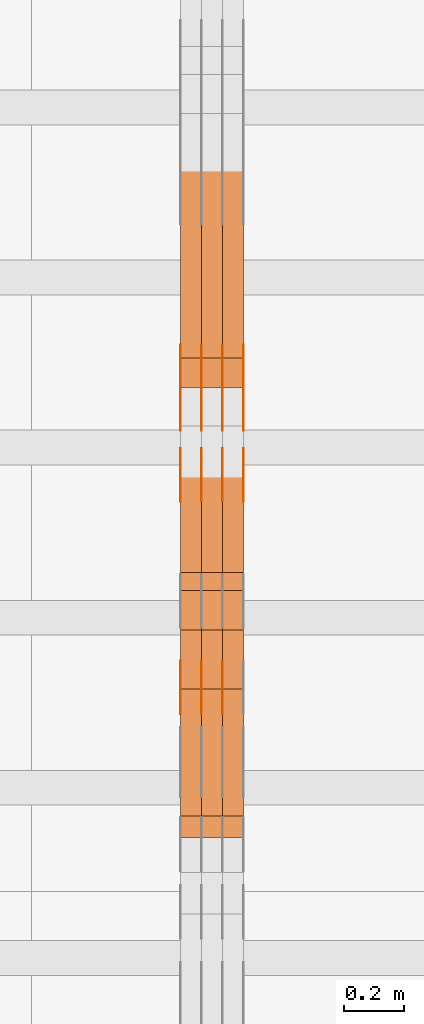
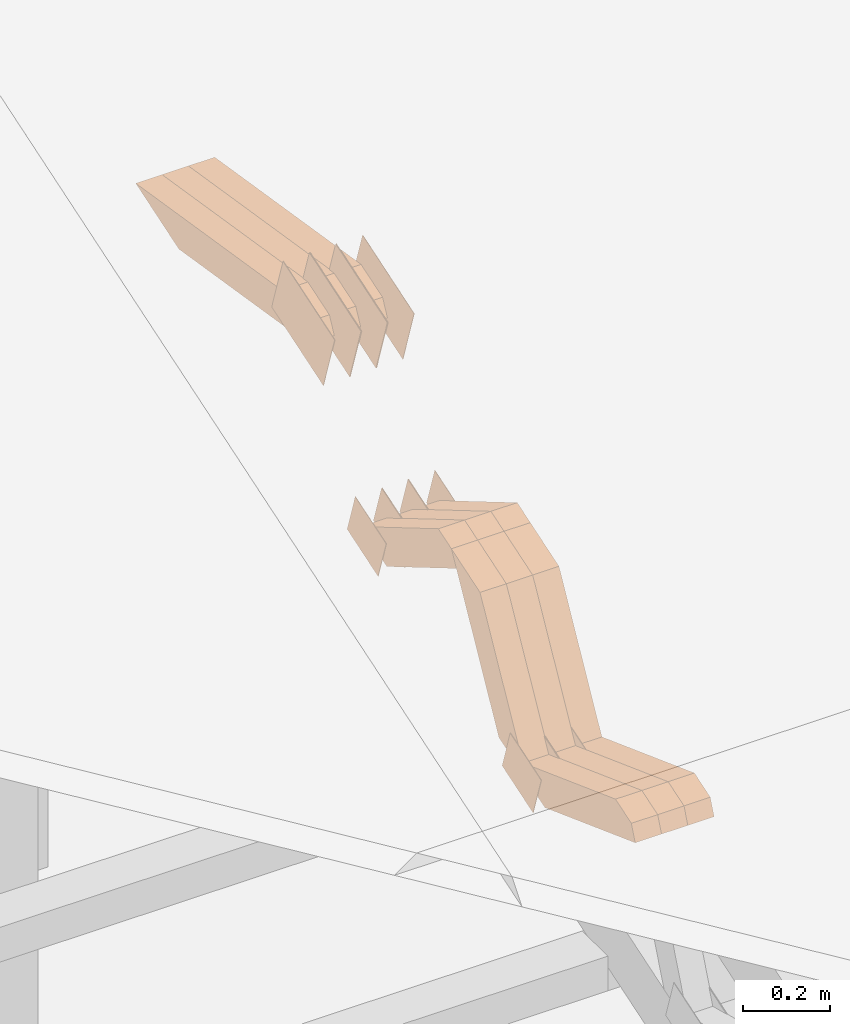
# One storey, part 71 of 385: 28 proxies.
"""IFC2X3 building model written with IfcOpenShell, lengths in millimetres."""

from ifc_helpers import new_model, entity, si_unit, converted_unit, derived_unit, direction, frame, origin, place, context, subcontext, project, spatial, polyline, outline, extrude, source, transform, mapped, material, type_object, type_shapes, element, save


model = new_model("IFC2X3")

# Units and contexts
model_context = context("Model", 3, precision=0.01, world=origin(), true_north=direction((6.12303176911189e-17, 1.0)))
body_context = subcontext(model_context, "Body", "Model", "MODEL_VIEW")
ifc_project = project(units=[si_unit("LENGTHUNIT", "METRE", prefix="MILLI"), si_unit("AREAUNIT", "SQUARE_METRE"), si_unit("VOLUMEUNIT", "CUBIC_METRE"), converted_unit("PLANEANGLEUNIT", "DEGREE", entity("IfcRatioMeasure", 0.0174532925199433), si_unit("PLANEANGLEUNIT", "RADIAN"), dimensions=[0, 0, 0, 0, 0, 0, 0]), si_unit("MASSUNIT", "GRAM", prefix="KILO"), derived_unit("MASSDENSITYUNIT", [(si_unit("MASSUNIT", "GRAM", prefix="KILO"), 1), (si_unit("LENGTHUNIT", "METRE"), -3)]), si_unit("TIMEUNIT", "SECOND"), si_unit("FREQUENCYUNIT", "HERTZ"), si_unit("THERMODYNAMICTEMPERATUREUNIT", "DEGREE_CELSIUS"), derived_unit("THERMALTRANSMITTANCEUNIT", [(si_unit("MASSUNIT", "GRAM", prefix="KILO"), 1), (si_unit("THERMODYNAMICTEMPERATUREUNIT", "KELVIN"), -1), (si_unit("TIMEUNIT", "SECOND"), -3)]), derived_unit("VOLUMETRICFLOWRATEUNIT", [(si_unit("LENGTHUNIT", "METRE"), 3), (si_unit("TIMEUNIT", "SECOND"), -1)]), si_unit("ELECTRICCURRENTUNIT", "AMPERE"), si_unit("ELECTRICVOLTAGEUNIT", "VOLT"), si_unit("POWERUNIT", "WATT"), si_unit("FORCEUNIT", "NEWTON", prefix="KILO"), si_unit("ILLUMINANCEUNIT", "LUX"), si_unit("LUMINOUSFLUXUNIT", "LUMEN"), si_unit("LUMINOUSINTENSITYUNIT", "CANDELA"), derived_unit("USERDEFINED", [(si_unit("MASSUNIT", "GRAM", prefix="KILO"), -1), (si_unit("LENGTHUNIT", "METRE"), -2), (si_unit("TIMEUNIT", "SECOND"), 3), (si_unit("LUMINOUSFLUXUNIT", "LUMEN"), 1)]), derived_unit("LINEARVELOCITYUNIT", [(si_unit("LENGTHUNIT", "METRE"), 1), (si_unit("TIMEUNIT", "SECOND"), -1)]), si_unit("PRESSUREUNIT", "PASCAL"), derived_unit("USERDEFINED", [(si_unit("LENGTHUNIT", "METRE"), -2), (si_unit("MASSUNIT", "GRAM", prefix="KILO"), 1), (si_unit("TIMEUNIT", "SECOND"), -2)])], contexts=[model_context])

# Site, building, storey
site_placement = place(None, origin())
site = spatial("IfcSite", under=ifc_project, at=site_placement, CompositionType="ELEMENT")
building_placement = place(site_placement, origin())
building = spatial("IfcBuilding", under=site, at=building_placement, CompositionType="ELEMENT")
storey_placement = place(building_placement, origin())
storey = spatial("IfcBuildingStorey", under=building, at=storey_placement, Name="Default", CompositionType="ELEMENT", Elevation=0.0)

# Proxies
ifc_material_1 = material(Name="IfcSurfaceStyle #175620")
building_element_proxy_type_1 = type_object("IfcBuildingElementProxyType", PredefinedType="NOTDEFINED", material=ifc_material_1)
shared_shape_1 = source(origin(), body_context, "Body", "SweptSolid", [
    extrude(outline(polyline([(-75.0008041947458, -59.9996998629349), (75.0007893252423, -59.9996998629349), (75.0008041947458, 59.9996998629349), (-75.0007893252423, 59.9996998629349), (-75.0008041947458, -59.9996998629349)])), frame((75.0008041947458, 60.0002282421692, 0.0), z_axis=(0.0, 0.0, 1.0), x_axis=(-1.0, 0.0, 0.0)), (0.0, 0.0, 1.0), 1.3),
])
type_shapes(building_element_proxy_type_1, [shared_shape_1])
proxy_1_placement = place(building_placement, frame((12316.3, 9291.048828125, 2194.94482421875), z_axis=(-1.0, 0.0, 0.0), x_axis=(0.0, 0.951056516295124, 0.309016994375039)))
element("IfcBuildingElementProxy", 1, at=proxy_1_placement, inside=storey, type_object=building_element_proxy_type_1, material=ifc_material_1, context=body_context, shape_type="MappedRepresentation", body=[
    mapped(shared_shape_1, transform((0.0, 0.0, 0.0), scale=1.0)),
])
ifc_material_2 = material(Name="IfcSurfaceStyle #175563")
building_element_proxy_type_2 = type_object("IfcBuildingElementProxyType", PredefinedType="NOTDEFINED", material=ifc_material_2)
shared_shape_2 = source(origin(), body_context, "Body", "SweptSolid", [
    extrude(outline(polyline([(-75.0008041947458, -59.9996998629349), (75.0007893252423, -59.9996998629349), (75.0008041947458, 59.9996998629349), (-75.0007893252423, 59.9996998629349), (-75.0008041947458, -59.9996998629349)])), frame((75.0008041947458, 60.0002282421692, 0.0), z_axis=(0.0, 0.0, 1.0), x_axis=(-1.0, 0.0, 0.0)), (0.0, 0.0, 1.0), 1.29999999999999),
])
type_shapes(building_element_proxy_type_2, [shared_shape_2])
proxy_2_placement = place(building_placement, frame((12245.0, 9291.048828125, 2194.94482421875), z_axis=(-1.0, 0.0, 0.0), x_axis=(0.0, 0.951056516295124, 0.309016994375039)))
element("IfcBuildingElementProxy", 2, at=proxy_2_placement, inside=storey, type_object=building_element_proxy_type_2, material=ifc_material_2, context=body_context, shape_type="MappedRepresentation", body=[
    mapped(shared_shape_2, transform((0.0, 0.0, 0.0), scale=1.0)),
])
ifc_material_3 = material(Name="IfcSurfaceStyle #175506")
building_element_proxy_type_3 = type_object("IfcBuildingElementProxyType", PredefinedType="NOTDEFINED", material=ifc_material_3)
shared_shape_3 = source(origin(), body_context, "Body", "SweptSolid", [
    extrude(outline(polyline([(-75.0008041947458, -59.9996998629349), (75.0007893252423, -59.9996998629349), (75.0008041947458, 59.9996998629349), (-75.0007893252423, 59.9996998629349), (-75.0008041947458, -59.9996998629349)])), frame((75.0008041947458, 60.0002282421692, 0.0), z_axis=(0.0, 0.0, 1.0), x_axis=(-1.0, 0.0, 0.0)), (0.0, 0.0, 1.0), 1.29999999999999),
])
type_shapes(building_element_proxy_type_3, [shared_shape_3])
proxy_3_placement = place(building_placement, frame((12246.3, 9291.048828125, 2194.94482421875), z_axis=(-1.0, 0.0, 0.0), x_axis=(0.0, 0.951056516295124, 0.309016994375039)))
element("IfcBuildingElementProxy", 3, at=proxy_3_placement, inside=storey, type_object=building_element_proxy_type_3, material=ifc_material_3, context=body_context, shape_type="MappedRepresentation", body=[
    mapped(shared_shape_3, transform((0.0, 0.0, 0.0), scale=1.0)),
])
ifc_material_4 = material(Name="IfcSurfaceStyle #175449")
building_element_proxy_type_4 = type_object("IfcBuildingElementProxyType", PredefinedType="NOTDEFINED", material=ifc_material_4)
shared_shape_4 = source(origin(), body_context, "Body", "SweptSolid", [
    extrude(outline(polyline([(-75.0008041947458, -59.9996998629349), (75.0007893252423, -59.9996998629349), (75.0008041947458, 59.9996998629349), (-75.0007893252423, 59.9996998629349), (-75.0008041947458, -59.9996998629349)])), frame((75.0008041947458, 60.0002282421692, 0.0), z_axis=(0.0, 0.0, 1.0), x_axis=(-1.0, 0.0, 0.0)), (0.0, 0.0, 1.0), 1.29999999999999),
])
type_shapes(building_element_proxy_type_4, [shared_shape_4])
proxy_4_placement = place(building_placement, frame((12175.0, 9291.048828125, 2194.94482421875), z_axis=(-1.0, 0.0, 0.0), x_axis=(0.0, 0.951056516295124, 0.309016994375039)))
element("IfcBuildingElementProxy", 4, at=proxy_4_placement, inside=storey, type_object=building_element_proxy_type_4, material=ifc_material_4, context=body_context, shape_type="MappedRepresentation", body=[
    mapped(shared_shape_4, transform((0.0, 0.0, 0.0), scale=1.0)),
])
ifc_material_5 = material(Name="IfcSurfaceStyle #175392")
building_element_proxy_type_5 = type_object("IfcBuildingElementProxyType", PredefinedType="NOTDEFINED", material=ifc_material_5)
shared_shape_5 = source(origin(), body_context, "Body", "SweptSolid", [
    extrude(outline(polyline([(-124.999432723313, -83.9999457831645), (125.000177551971, -83.9999457831645), (124.999395001513, 83.9999457831646), (-125.000139830171, 83.9999457831645), (-124.999432723313, -83.9999457831645)])), frame((125.000177551971, 84.0001194377192, 0.0), z_axis=(0.0, 0.0, 1.0), x_axis=(-1.0, 0.0, 0.0)), (0.0, 0.0, 1.0), 1.3),
])
type_shapes(building_element_proxy_type_5, [shared_shape_5])
proxy_5_placement = place(building_placement, frame((12386.3, 10242.0968435406, 2855.88278137571), z_axis=(-1.0, 0.0, 0.0), x_axis=(0.0, 0.951056516295154, 0.309016994374948)))
element("IfcBuildingElementProxy", 5, at=proxy_5_placement, inside=storey, type_object=building_element_proxy_type_5, material=ifc_material_5, context=body_context, shape_type="MappedRepresentation", body=[
    mapped(shared_shape_5, transform((0.0, 0.0, 0.0), scale=1.0)),
])
ifc_material_6 = material(Name="IfcSurfaceStyle #175335")
building_element_proxy_type_6 = type_object("IfcBuildingElementProxyType", PredefinedType="NOTDEFINED", material=ifc_material_6)
shared_shape_6 = source(origin(), body_context, "Body", "SweptSolid", [
    extrude(outline(polyline([(-124.999432723313, -83.9999457831645), (125.000177551971, -83.9999457831645), (124.999395001513, 83.9999457831646), (-125.000139830171, 83.9999457831645), (-124.999432723313, -83.9999457831645)])), frame((125.000177551971, 84.0001194377192, 0.0), z_axis=(0.0, 0.0, 1.0), x_axis=(-1.0, 0.0, 0.0)), (0.0, 0.0, 1.0), 1.3),
])
type_shapes(building_element_proxy_type_6, [shared_shape_6])
proxy_6_placement = place(building_placement, frame((12315.0, 10242.0968435406, 2855.88278137571), z_axis=(-1.0, 0.0, 0.0), x_axis=(0.0, 0.951056516295154, 0.309016994374948)))
element("IfcBuildingElementProxy", 6, at=proxy_6_placement, inside=storey, type_object=building_element_proxy_type_6, material=ifc_material_6, context=body_context, shape_type="MappedRepresentation", body=[
    mapped(shared_shape_6, transform((0.0, 0.0, 0.0), scale=1.0)),
])
ifc_material_7 = material(Name="IfcSurfaceStyle #175278")
building_element_proxy_type_7 = type_object("IfcBuildingElementProxyType", PredefinedType="NOTDEFINED", material=ifc_material_7)
shared_shape_7 = source(origin(), body_context, "Body", "SweptSolid", [
    extrude(outline(polyline([(-124.999432723313, -83.9999457831645), (125.000177551971, -83.9999457831645), (124.999395001513, 83.9999457831646), (-125.000139830171, 83.9999457831645), (-124.999432723313, -83.9999457831645)])), frame((125.000177551971, 84.0001194377192, 0.0), z_axis=(0.0, 0.0, 1.0), x_axis=(-1.0, 0.0, 0.0)), (0.0, 0.0, 1.0), 1.3),
])
type_shapes(building_element_proxy_type_7, [shared_shape_7])
proxy_7_placement = place(building_placement, frame((12316.3, 10242.0968435406, 2855.88278137571), z_axis=(-1.0, 0.0, 0.0), x_axis=(0.0, 0.951056516295154, 0.309016994374948)))
element("IfcBuildingElementProxy", 7, at=proxy_7_placement, inside=storey, type_object=building_element_proxy_type_7, material=ifc_material_7, context=body_context, shape_type="MappedRepresentation", body=[
    mapped(shared_shape_7, transform((0.0, 0.0, 0.0), scale=1.0)),
])
ifc_material_8 = material(Name="IfcSurfaceStyle #175221")
building_element_proxy_type_8 = type_object("IfcBuildingElementProxyType", PredefinedType="NOTDEFINED", material=ifc_material_8)
shared_shape_8 = source(origin(), body_context, "Body", "SweptSolid", [
    extrude(outline(polyline([(-124.999432723313, -83.9999457831645), (125.000177551971, -83.9999457831645), (124.999395001513, 83.9999457831646), (-125.000139830171, 83.9999457831645), (-124.999432723313, -83.9999457831645)])), frame((125.000177551971, 84.0001194377192, 0.0), z_axis=(0.0, 0.0, 1.0), x_axis=(-1.0, 0.0, 0.0)), (0.0, 0.0, 1.0), 1.29999999999998),
])
type_shapes(building_element_proxy_type_8, [shared_shape_8])
proxy_8_placement = place(building_placement, frame((12245.0, 10242.0968435406, 2855.88278137571), z_axis=(-1.0, 0.0, 0.0), x_axis=(0.0, 0.951056516295154, 0.309016994374948)))
element("IfcBuildingElementProxy", 8, at=proxy_8_placement, inside=storey, type_object=building_element_proxy_type_8, material=ifc_material_8, context=body_context, shape_type="MappedRepresentation", body=[
    mapped(shared_shape_8, transform((0.0, 0.0, 0.0), scale=1.0)),
])
ifc_material_9 = material(Name="IfcSurfaceStyle #175164")
building_element_proxy_type_9 = type_object("IfcBuildingElementProxyType", PredefinedType="NOTDEFINED", material=ifc_material_9)
shared_shape_9 = source(origin(), body_context, "Body", "SweptSolid", [
    extrude(outline(polyline([(-124.999432723313, -83.9999457831645), (125.000177551971, -83.9999457831645), (124.999395001513, 83.9999457831646), (-125.000139830171, 83.9999457831645), (-124.999432723313, -83.9999457831645)])), frame((125.000177551971, 84.0001194377192, 0.0), z_axis=(0.0, 0.0, 1.0), x_axis=(-1.0, 0.0, 0.0)), (0.0, 0.0, 1.0), 1.29999999999998),
])
type_shapes(building_element_proxy_type_9, [shared_shape_9])
proxy_9_placement = place(building_placement, frame((12246.3, 10242.0968435406, 2855.88278137571), z_axis=(-1.0, 0.0, 0.0), x_axis=(0.0, 0.951056516295154, 0.309016994374948)))
element("IfcBuildingElementProxy", 9, at=proxy_9_placement, inside=storey, type_object=building_element_proxy_type_9, material=ifc_material_9, context=body_context, shape_type="MappedRepresentation", body=[
    mapped(shared_shape_9, transform((0.0, 0.0, 0.0), scale=1.0)),
])
ifc_material_10 = material(Name="IfcSurfaceStyle #175107")
building_element_proxy_type_10 = type_object("IfcBuildingElementProxyType", PredefinedType="NOTDEFINED", material=ifc_material_10)
shared_shape_10 = source(origin(), body_context, "Body", "SweptSolid", [
    extrude(outline(polyline([(-124.999432723313, -83.9999457831645), (125.000177551971, -83.9999457831645), (124.999395001513, 83.9999457831646), (-125.000139830171, 83.9999457831645), (-124.999432723313, -83.9999457831645)])), frame((125.000177551971, 84.0001194377192, 0.0), z_axis=(0.0, 0.0, 1.0), x_axis=(-1.0, 0.0, 0.0)), (0.0, 0.0, 1.0), 1.29999999999998),
])
type_shapes(building_element_proxy_type_10, [shared_shape_10])
proxy_10_placement = place(building_placement, frame((12175.0, 10242.0968435406, 2855.88278137571), z_axis=(-1.0, 0.0, 0.0), x_axis=(0.0, 0.951056516295154, 0.309016994374948)))
element("IfcBuildingElementProxy", 10, at=proxy_10_placement, inside=storey, type_object=building_element_proxy_type_10, material=ifc_material_10, context=body_context, shape_type="MappedRepresentation", body=[
    mapped(shared_shape_10, transform((0.0, 0.0, 0.0), scale=1.0)),
])
ifc_material_11 = material(Name="IfcSurfaceStyle #173682")
building_element_proxy_type_11 = type_object("IfcBuildingElementProxyType", PredefinedType="NOTDEFINED", material=ifc_material_11)
shared_shape_11 = source(origin(), body_context, "Body", "SweptSolid", [
    extrude(outline(polyline([(-74.9998754286189, -60.0000016373433), (74.9998605591118, -60.0000016373433), (74.9998754286189, 60.0000016373433), (-74.9998605591118, 60.0000016373433), (-74.9998754286189, -60.0000016373433)])), frame((74.9999131819004, 60.0000016373433, 0.0), z_axis=(0.0, 0.0, 1.0), x_axis=(-1.0, 0.0, 0.0)), (0.0, 0.0, 1.0), 1.3),
])
type_shapes(building_element_proxy_type_11, [shared_shape_11])
proxy_11_placement = place(building_placement, frame((12386.3, 10004.8612689908, 2426.87628052724), z_axis=(-1.0, 0.0, 0.0), x_axis=(0.0, 0.951056516295124, 0.309016994375039)))
element("IfcBuildingElementProxy", 11, at=proxy_11_placement, inside=storey, type_object=building_element_proxy_type_11, material=ifc_material_11, context=body_context, shape_type="MappedRepresentation", body=[
    mapped(shared_shape_11, transform((0.0, 0.0, 0.0), scale=1.0)),
])
ifc_material_12 = material(Name="IfcSurfaceStyle #173625")
building_element_proxy_type_12 = type_object("IfcBuildingElementProxyType", PredefinedType="NOTDEFINED", material=ifc_material_12)
shared_shape_12 = source(origin(), body_context, "Body", "SweptSolid", [
    extrude(outline(polyline([(-74.9998754286189, -60.0000016373433), (74.9998605591118, -60.0000016373433), (74.9998754286189, 60.0000016373433), (-74.9998605591118, 60.0000016373433), (-74.9998754286189, -60.0000016373433)])), frame((74.9999131819004, 60.0000016373433, 0.0), z_axis=(0.0, 0.0, 1.0), x_axis=(-1.0, 0.0, 0.0)), (0.0, 0.0, 1.0), 1.3),
])
type_shapes(building_element_proxy_type_12, [shared_shape_12])
proxy_12_placement = place(building_placement, frame((12315.0, 10004.8612689908, 2426.87628052724), z_axis=(-1.0, 0.0, 0.0), x_axis=(0.0, 0.951056516295124, 0.309016994375039)))
element("IfcBuildingElementProxy", 12, at=proxy_12_placement, inside=storey, type_object=building_element_proxy_type_12, material=ifc_material_12, context=body_context, shape_type="MappedRepresentation", body=[
    mapped(shared_shape_12, transform((0.0, 0.0, 0.0), scale=1.0)),
])
ifc_material_13 = material(Name="IfcSurfaceStyle #173568")
building_element_proxy_type_13 = type_object("IfcBuildingElementProxyType", PredefinedType="NOTDEFINED", material=ifc_material_13)
shared_shape_13 = source(origin(), body_context, "Body", "SweptSolid", [
    extrude(outline(polyline([(-74.9998754286189, -60.0000016373433), (74.9998605591118, -60.0000016373433), (74.9998754286189, 60.0000016373433), (-74.9998605591118, 60.0000016373433), (-74.9998754286189, -60.0000016373433)])), frame((74.9999131819004, 60.0000016373433, 0.0), z_axis=(0.0, 0.0, 1.0), x_axis=(-1.0, 0.0, 0.0)), (0.0, 0.0, 1.0), 1.3),
])
type_shapes(building_element_proxy_type_13, [shared_shape_13])
proxy_13_placement = place(building_placement, frame((12316.3, 10004.8612689908, 2426.87628052724), z_axis=(-1.0, 0.0, 0.0), x_axis=(0.0, 0.951056516295124, 0.309016994375039)))
element("IfcBuildingElementProxy", 13, at=proxy_13_placement, inside=storey, type_object=building_element_proxy_type_13, material=ifc_material_13, context=body_context, shape_type="MappedRepresentation", body=[
    mapped(shared_shape_13, transform((0.0, 0.0, 0.0), scale=1.0)),
])
ifc_material_14 = material(Name="IfcSurfaceStyle #173511")
building_element_proxy_type_14 = type_object("IfcBuildingElementProxyType", PredefinedType="NOTDEFINED", material=ifc_material_14)
shared_shape_14 = source(origin(), body_context, "Body", "SweptSolid", [
    extrude(outline(polyline([(-74.9998754286189, -60.0000016373433), (74.9998605591118, -60.0000016373433), (74.9998754286189, 60.0000016373433), (-74.9998605591118, 60.0000016373433), (-74.9998754286189, -60.0000016373433)])), frame((74.9999131819004, 60.0000016373433, 0.0), z_axis=(0.0, 0.0, 1.0), x_axis=(-1.0, 0.0, 0.0)), (0.0, 0.0, 1.0), 1.29999999999999),
])
type_shapes(building_element_proxy_type_14, [shared_shape_14])
proxy_14_placement = place(building_placement, frame((12245.0, 10004.8612689908, 2426.87628052724), z_axis=(-1.0, 0.0, 0.0), x_axis=(0.0, 0.951056516295124, 0.309016994375039)))
element("IfcBuildingElementProxy", 14, at=proxy_14_placement, inside=storey, type_object=building_element_proxy_type_14, material=ifc_material_14, context=body_context, shape_type="MappedRepresentation", body=[
    mapped(shared_shape_14, transform((0.0, 0.0, 0.0), scale=1.0)),
])
ifc_material_15 = material(Name="IfcSurfaceStyle #173454")
building_element_proxy_type_15 = type_object("IfcBuildingElementProxyType", PredefinedType="NOTDEFINED", material=ifc_material_15)
shared_shape_15 = source(origin(), body_context, "Body", "SweptSolid", [
    extrude(outline(polyline([(-74.9998754286189, -60.0000016373433), (74.9998605591118, -60.0000016373433), (74.9998754286189, 60.0000016373433), (-74.9998605591118, 60.0000016373433), (-74.9998754286189, -60.0000016373433)])), frame((74.9999131819004, 60.0000016373433, 0.0), z_axis=(0.0, 0.0, 1.0), x_axis=(-1.0, 0.0, 0.0)), (0.0, 0.0, 1.0), 1.29999999999999),
])
type_shapes(building_element_proxy_type_15, [shared_shape_15])
proxy_15_placement = place(building_placement, frame((12246.3, 10004.8612689908, 2426.87628052724), z_axis=(-1.0, 0.0, 0.0), x_axis=(0.0, 0.951056516295124, 0.309016994375039)))
element("IfcBuildingElementProxy", 15, at=proxy_15_placement, inside=storey, type_object=building_element_proxy_type_15, material=ifc_material_15, context=body_context, shape_type="MappedRepresentation", body=[
    mapped(shared_shape_15, transform((0.0, 0.0, 0.0), scale=1.0)),
])
ifc_material_16 = material(Name="IfcSurfaceStyle #173397")
building_element_proxy_type_16 = type_object("IfcBuildingElementProxyType", PredefinedType="NOTDEFINED", material=ifc_material_16)
shared_shape_16 = source(origin(), body_context, "Body", "SweptSolid", [
    extrude(outline(polyline([(-74.9998754286189, -60.0000016373433), (74.9998605591118, -60.0000016373433), (74.9998754286189, 60.0000016373433), (-74.9998605591118, 60.0000016373433), (-74.9998754286189, -60.0000016373433)])), frame((74.9999131819004, 60.0000016373433, 0.0), z_axis=(0.0, 0.0, 1.0), x_axis=(-1.0, 0.0, 0.0)), (0.0, 0.0, 1.0), 1.29999999999999),
])
type_shapes(building_element_proxy_type_16, [shared_shape_16])
proxy_16_placement = place(building_placement, frame((12175.0, 10004.8612689908, 2426.87628052724), z_axis=(-1.0, 0.0, 0.0), x_axis=(0.0, 0.951056516295124, 0.309016994375039)))
element("IfcBuildingElementProxy", 16, at=proxy_16_placement, inside=storey, type_object=building_element_proxy_type_16, material=ifc_material_16, context=body_context, shape_type="MappedRepresentation", body=[
    mapped(shared_shape_16, transform((0.0, 0.0, 0.0), scale=1.0)),
])
ifc_material_17 = material(Name="IfcSurfaceStyle #153360")
building_element_proxy_type_17 = type_object("IfcBuildingElementProxyType", Name="T1-W5 153358", PredefinedType="NOTDEFINED", material=ifc_material_17)
shared_shape_17 = source(origin(), body_context, "Body", "SweptSolid", [
    extrude(outline(polyline([(-301.214270081322, -47.5000783565111), (303.980395954293, -47.5000783565111), (288.664123931657, 0.000197935560590153), (195.704076557203, 47.4999793887309), (-487.134326361831, 47.4999793887309), (-301.214270081322, -47.5000783565111)])), frame((303.980395954293, 47.5001815410909, 0.0), z_axis=(0.0, 0.0, 1.0), x_axis=(-1.0, 0.0, 0.0)), (0.0, 0.0, 1.0), 70.0),
])
type_shapes(building_element_proxy_type_17, [shared_shape_17])
proxy_17_placement = place(building_placement, frame((12385.0, 10379.2051671398, 2863.91176079486), z_axis=(-1.0, 0.0, 0.0), x_axis=(0.0, 0.987508363398486, -0.1575665961365)))
element("IfcBuildingElementProxy", 17, at=proxy_17_placement, inside=storey, type_object=building_element_proxy_type_17, material=ifc_material_17, Name="T1-W5", context=body_context, shape_type="MappedRepresentation", body=[
    mapped(shared_shape_17, transform((0.0, 0.0, 0.0), scale=1.0)),
])
ifc_material_18 = material(Name="IfcSurfaceStyle #153294")
building_element_proxy_type_18 = type_object("IfcBuildingElementProxyType", Name="T1-W5 153292", PredefinedType="NOTDEFINED", material=ifc_material_18)
shared_shape_18 = source(origin(), body_context, "Body", "SweptSolid", [
    extrude(outline(polyline([(-301.214270081322, -47.5000783565111), (303.980395954293, -47.5000783565111), (288.664123931657, 0.000197935560590153), (195.704076557203, 47.4999793887309), (-487.134326361831, 47.4999793887309), (-301.214270081322, -47.5000783565111)])), frame((303.980395954293, 47.5001815410909, 0.0), z_axis=(0.0, 0.0, 1.0), x_axis=(-1.0, 0.0, 0.0)), (0.0, 0.0, 1.0), 70.0),
])
type_shapes(building_element_proxy_type_18, [shared_shape_18])
proxy_18_placement = place(building_placement, frame((12315.0, 10379.2051671398, 2863.91176079486), z_axis=(-1.0, 0.0, 0.0), x_axis=(0.0, 0.987508363398486, -0.1575665961365)))
element("IfcBuildingElementProxy", 18, at=proxy_18_placement, inside=storey, type_object=building_element_proxy_type_18, material=ifc_material_18, Name="T1-W5", context=body_context, shape_type="MappedRepresentation", body=[
    mapped(shared_shape_18, transform((0.0, 0.0, 0.0), scale=1.0)),
])
ifc_material_19 = material(Name="IfcSurfaceStyle #153228")
building_element_proxy_type_19 = type_object("IfcBuildingElementProxyType", Name="T1-W5 153226", PredefinedType="NOTDEFINED", material=ifc_material_19)
shared_shape_19 = source(origin(), body_context, "Body", "SweptSolid", [
    extrude(outline(polyline([(-301.214270081322, -47.5000783565111), (303.980395954293, -47.5000783565111), (288.664123931657, 0.000197935560590153), (195.704076557203, 47.4999793887309), (-487.134326361831, 47.4999793887309), (-301.214270081322, -47.5000783565111)])), frame((303.980395954293, 47.5001815410909, 0.0), z_axis=(0.0, 0.0, 1.0), x_axis=(-1.0, 0.0, 0.0)), (0.0, 0.0, 1.0), 70.0),
])
type_shapes(building_element_proxy_type_19, [shared_shape_19])
proxy_19_placement = place(building_placement, frame((12245.0, 10379.2051671398, 2863.91176079486), z_axis=(-1.0, 0.0, 0.0), x_axis=(0.0, 0.987508363398486, -0.1575665961365)))
element("IfcBuildingElementProxy", 19, at=proxy_19_placement, inside=storey, type_object=building_element_proxy_type_19, material=ifc_material_19, Name="T1-W5", context=body_context, shape_type="MappedRepresentation", body=[
    mapped(shared_shape_19, transform((0.0, 0.0, 0.0), scale=1.0)),
])
ifc_material_20 = material(Name="IfcSurfaceStyle #152568")
building_element_proxy_type_20 = type_object("IfcBuildingElementProxyType", Name="T1-W43 152566", PredefinedType="NOTDEFINED", material=ifc_material_20)
shared_shape_20 = source(origin(), body_context, "Body", "SweptSolid", [
    extrude(outline(polyline([(-198.159905426436, -47.4999961988362), (173.155878681738, -47.4999961988362), (174.585865234707, -0.00038778214839239), (132.582704932703, 47.5001900899104), (-282.164543422712, 47.5001900899104), (-198.159905426436, -47.4999961988362)])), frame((174.585865234707, 47.5001900899104, 0.0), z_axis=(0.0, 0.0, 1.0), x_axis=(-1.0, 0.0, 0.0)), (0.0, 0.0, 1.0), 70.0),
])
type_shapes(building_element_proxy_type_20, [shared_shape_20])
proxy_20_placement = place(building_placement, frame((12385.0, 9730.71877771152, 2634.4881681647), z_axis=(-1.0, 0.0, 0.0), x_axis=(0.0, 0.861495156633645, -0.507765787639115)))
element("IfcBuildingElementProxy", 20, at=proxy_20_placement, inside=storey, type_object=building_element_proxy_type_20, material=ifc_material_20, Name="T1-W43", context=body_context, shape_type="MappedRepresentation", body=[
    mapped(shared_shape_20, transform((0.0, 0.0, 0.0), scale=1.0)),
])
ifc_material_21 = material(Name="IfcSurfaceStyle #152502")
building_element_proxy_type_21 = type_object("IfcBuildingElementProxyType", Name="T1-W43 152500", PredefinedType="NOTDEFINED", material=ifc_material_21)
shared_shape_21 = source(origin(), body_context, "Body", "SweptSolid", [
    extrude(outline(polyline([(-198.159905426436, -47.4999961988362), (173.155878681738, -47.4999961988362), (174.585865234707, -0.00038778214839239), (132.582704932703, 47.5001900899104), (-282.164543422712, 47.5001900899104), (-198.159905426436, -47.4999961988362)])), frame((174.585865234707, 47.5001900899104, 0.0), z_axis=(0.0, 0.0, 1.0), x_axis=(-1.0, 0.0, 0.0)), (0.0, 0.0, 1.0), 70.0),
])
type_shapes(building_element_proxy_type_21, [shared_shape_21])
proxy_21_placement = place(building_placement, frame((12315.0, 9730.71877771152, 2634.4881681647), z_axis=(-1.0, 0.0, 0.0), x_axis=(0.0, 0.861495156633645, -0.507765787639115)))
element("IfcBuildingElementProxy", 21, at=proxy_21_placement, inside=storey, type_object=building_element_proxy_type_21, material=ifc_material_21, Name="T1-W43", context=body_context, shape_type="MappedRepresentation", body=[
    mapped(shared_shape_21, transform((0.0, 0.0, 0.0), scale=1.0)),
])
ifc_material_22 = material(Name="IfcSurfaceStyle #152436")
building_element_proxy_type_22 = type_object("IfcBuildingElementProxyType", Name="T1-W43 152434", PredefinedType="NOTDEFINED", material=ifc_material_22)
shared_shape_22 = source(origin(), body_context, "Body", "SweptSolid", [
    extrude(outline(polyline([(-198.159905426436, -47.4999961988362), (173.155878681738, -47.4999961988362), (174.585865234707, -0.00038778214839239), (132.582704932703, 47.5001900899104), (-282.164543422712, 47.5001900899104), (-198.159905426436, -47.4999961988362)])), frame((174.585865234707, 47.5001900899104, 0.0), z_axis=(0.0, 0.0, 1.0), x_axis=(-1.0, 0.0, 0.0)), (0.0, 0.0, 1.0), 70.0),
])
type_shapes(building_element_proxy_type_22, [shared_shape_22])
proxy_22_placement = place(building_placement, frame((12245.0, 9730.71877771152, 2634.4881681647), z_axis=(-1.0, 0.0, 0.0), x_axis=(0.0, 0.861495156633645, -0.507765787639115)))
element("IfcBuildingElementProxy", 22, at=proxy_22_placement, inside=storey, type_object=building_element_proxy_type_22, material=ifc_material_22, Name="T1-W43", context=body_context, shape_type="MappedRepresentation", body=[
    mapped(shared_shape_22, transform((0.0, 0.0, 0.0), scale=1.0)),
])
ifc_material_23 = material(Name="IfcSurfaceStyle #152172")
building_element_proxy_type_23 = type_object("IfcBuildingElementProxyType", Name="T1-W33 152170", PredefinedType="NOTDEFINED", material=ifc_material_23)
shared_shape_23 = source(origin(), body_context, "Body", "SweptSolid", [
    extrude(outline(polyline([(-314.173070820175, -47.4997758466969), (139.635944117881, -47.4997758466969), (190.204920608233, 0.000348187720347082), (197.369205310989, 47.5001702328475), (-213.036999216928, 47.4990332728259), (-314.173070820175, -47.4997758466969)])), frame((197.369205310989, 47.5001702328475, 0.0), z_axis=(0.0, 0.0, 1.0), x_axis=(-1.0, 0.0, 0.0)), (0.0, 0.0, 1.0), 70.0),
])
type_shapes(building_element_proxy_type_23, [shared_shape_23])
proxy_23_placement = place(building_placement, frame((12385.0, 9376.96875, 2191.01977539063), z_axis=(-1.0, 0.0, 0.0), x_axis=(0.0, 0.481632628948835, 0.876373214293907)))
element("IfcBuildingElementProxy", 23, at=proxy_23_placement, inside=storey, type_object=building_element_proxy_type_23, material=ifc_material_23, Name="T1-W33", context=body_context, shape_type="MappedRepresentation", body=[
    mapped(shared_shape_23, transform((0.0, 0.0, 0.0), scale=1.0)),
])
ifc_material_24 = material(Name="IfcSurfaceStyle #152106")
building_element_proxy_type_24 = type_object("IfcBuildingElementProxyType", Name="T1-W33 152104", PredefinedType="NOTDEFINED", material=ifc_material_24)
shared_shape_24 = source(origin(), body_context, "Body", "SweptSolid", [
    extrude(outline(polyline([(-314.173070820175, -47.4997758466969), (139.635944117881, -47.4997758466969), (190.204920608233, 0.000348187720347082), (197.369205310989, 47.5001702328475), (-213.036999216928, 47.4990332728259), (-314.173070820175, -47.4997758466969)])), frame((197.369205310989, 47.5001702328475, 0.0), z_axis=(0.0, 0.0, 1.0), x_axis=(-1.0, 0.0, 0.0)), (0.0, 0.0, 1.0), 70.0),
])
type_shapes(building_element_proxy_type_24, [shared_shape_24])
proxy_24_placement = place(building_placement, frame((12315.0, 9376.96875, 2191.01977539063), z_axis=(-1.0, 0.0, 0.0), x_axis=(0.0, 0.481632628948835, 0.876373214293907)))
element("IfcBuildingElementProxy", 24, at=proxy_24_placement, inside=storey, type_object=building_element_proxy_type_24, material=ifc_material_24, Name="T1-W33", context=body_context, shape_type="MappedRepresentation", body=[
    mapped(shared_shape_24, transform((0.0, 0.0, 0.0), scale=1.0)),
])
ifc_material_25 = material(Name="IfcSurfaceStyle #152040")
building_element_proxy_type_25 = type_object("IfcBuildingElementProxyType", Name="T1-W33 152038", PredefinedType="NOTDEFINED", material=ifc_material_25)
shared_shape_25 = source(origin(), body_context, "Body", "SweptSolid", [
    extrude(outline(polyline([(-314.173070820175, -47.4997758466969), (139.635944117881, -47.4997758466969), (190.204920608233, 0.000348187720347082), (197.369205310989, 47.5001702328475), (-213.036999216928, 47.4990332728259), (-314.173070820175, -47.4997758466969)])), frame((197.369205310989, 47.5001702328475, 0.0), z_axis=(0.0, 0.0, 1.0), x_axis=(-1.0, 0.0, 0.0)), (0.0, 0.0, 1.0), 70.0),
])
type_shapes(building_element_proxy_type_25, [shared_shape_25])
proxy_25_placement = place(building_placement, frame((12245.0, 9376.96875, 2191.01977539063), z_axis=(-1.0, 0.0, 0.0), x_axis=(0.0, 0.481632628948835, 0.876373214293907)))
element("IfcBuildingElementProxy", 25, at=proxy_25_placement, inside=storey, type_object=building_element_proxy_type_25, material=ifc_material_25, Name="T1-W33", context=body_context, shape_type="MappedRepresentation", body=[
    mapped(shared_shape_25, transform((0.0, 0.0, 0.0), scale=1.0)),
])
ifc_material_26 = material(Name="IfcSurfaceStyle #151776")
building_element_proxy_type_26 = type_object("IfcBuildingElementProxyType", Name="T1-W25 151774", PredefinedType="NOTDEFINED", material=ifc_material_26)
shared_shape_26 = source(origin(), body_context, "Body", "SweptSolid", [
    extrude(outline(polyline([(-229.232772462784, -47.5001671709529), (214.075939394384, -47.5001671709529), (212.688957821661, -0.000141058964427199), (152.358910178478, 47.5002377004352), (-349.891034931738, 47.5002377004352), (-229.232772462784, -47.5001671709529)])), frame((214.075939394384, 47.5002377004352, 0.0), z_axis=(0.0, 0.0, 1.0), x_axis=(-1.0, 0.0, 0.0)), (0.0, 0.0, 1.0), 70.0),
])
type_shapes(building_element_proxy_type_26, [shared_shape_26])
proxy_26_placement = place(building_placement, frame((12385.0, 8892.81895960242, 2369.29665807578), z_axis=(-1.0, 0.0, 0.0), x_axis=(0.0, 0.938402514401222, -0.345544094097213)))
element("IfcBuildingElementProxy", 26, at=proxy_26_placement, inside=storey, type_object=building_element_proxy_type_26, material=ifc_material_26, Name="T1-W25", context=body_context, shape_type="MappedRepresentation", body=[
    mapped(shared_shape_26, transform((0.0, 0.0, 0.0), scale=1.0)),
])
ifc_material_27 = material(Name="IfcSurfaceStyle #151710")
building_element_proxy_type_27 = type_object("IfcBuildingElementProxyType", Name="T1-W25 151708", PredefinedType="NOTDEFINED", material=ifc_material_27)
shared_shape_27 = source(origin(), body_context, "Body", "SweptSolid", [
    extrude(outline(polyline([(-229.232772462784, -47.5001671709529), (214.075939394384, -47.5001671709529), (212.688957821661, -0.000141058964427199), (152.358910178478, 47.5002377004352), (-349.891034931738, 47.5002377004352), (-229.232772462784, -47.5001671709529)])), frame((214.075939394384, 47.5002377004352, 0.0), z_axis=(0.0, 0.0, 1.0), x_axis=(-1.0, 0.0, 0.0)), (0.0, 0.0, 1.0), 70.0),
])
type_shapes(building_element_proxy_type_27, [shared_shape_27])
proxy_27_placement = place(building_placement, frame((12315.0, 8892.81895960242, 2369.29665807578), z_axis=(-1.0, 0.0, 0.0), x_axis=(0.0, 0.938402514401222, -0.345544094097213)))
element("IfcBuildingElementProxy", 27, at=proxy_27_placement, inside=storey, type_object=building_element_proxy_type_27, material=ifc_material_27, Name="T1-W25", context=body_context, shape_type="MappedRepresentation", body=[
    mapped(shared_shape_27, transform((0.0, 0.0, 0.0), scale=1.0)),
])
ifc_material_28 = material(Name="IfcSurfaceStyle #151644")
building_element_proxy_type_28 = type_object("IfcBuildingElementProxyType", Name="T1-W25 151642", PredefinedType="NOTDEFINED", material=ifc_material_28)
shared_shape_28 = source(origin(), body_context, "Body", "SweptSolid", [
    extrude(outline(polyline([(-229.232772462784, -47.5001671709529), (214.075939394384, -47.5001671709529), (212.688957821661, -0.000141058964427199), (152.358910178478, 47.5002377004352), (-349.891034931738, 47.5002377004352), (-229.232772462784, -47.5001671709529)])), frame((214.075939394384, 47.5002377004352, 0.0), z_axis=(0.0, 0.0, 1.0), x_axis=(-1.0, 0.0, 0.0)), (0.0, 0.0, 1.0), 70.0),
])
type_shapes(building_element_proxy_type_28, [shared_shape_28])
proxy_28_placement = place(building_placement, frame((12245.0, 8892.81895960242, 2369.29665807578), z_axis=(-1.0, 0.0, 0.0), x_axis=(0.0, 0.938402514401222, -0.345544094097213)))
element("IfcBuildingElementProxy", 28, at=proxy_28_placement, inside=storey, type_object=building_element_proxy_type_28, material=ifc_material_28, Name="T1-W25", context=body_context, shape_type="MappedRepresentation", body=[
    mapped(shared_shape_28, transform((0.0, 0.0, 0.0), scale=1.0)),
])

save(model, "model.ifc")
